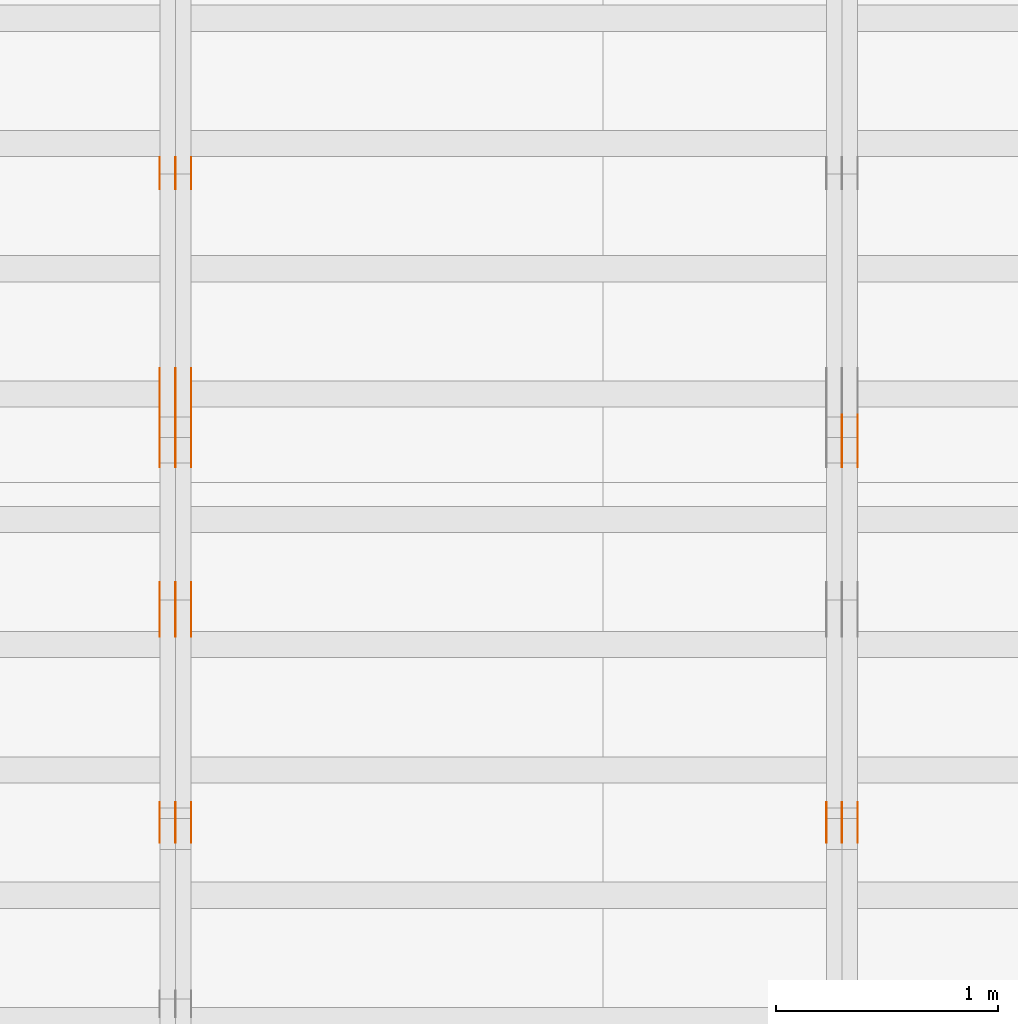
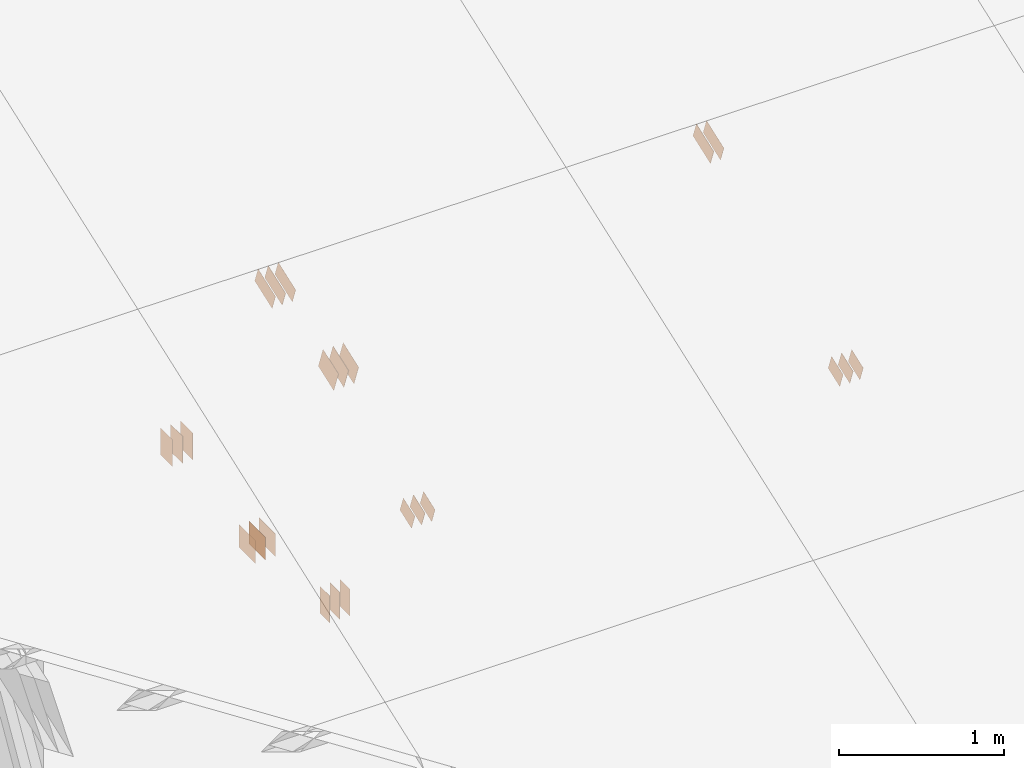
# One storey, part 74 of 189: 31 proxies.
"""IFC2X3 building model written with IfcOpenShell, lengths in millimetres."""

import ifcopenshell
import ifcopenshell.guid

model = None  # the IFC model being written
_history = None  # IfcOwnerHistory: only IFC2X3 demands one
_inside = {}  # id of a spatial element -> (the spatial element, [elements in it])
_under = {}  # id of a project, library or spatial element -> (it, [spatial elements below it])
_declared = {}  # id of a project -> (the project, [libraries it declares])
_typed = {}  # id of a type object -> (the type object, [elements of that type])
_made_of = {}  # id of a material, layer set ... -> (it, [elements and type objects made of it])


def new_model(schema):
    """Start an empty IFC model of exactly this schema.

    Asked for "IFC4X3", IfcOpenShell would pick the latest addendum, in which some entities
    have other attributes; the version numbers below select the first issue.
    IFC2X3 requires an IfcOwnerHistory on every rooted entity: one is made here for all.
    """
    global model, _history
    if schema == "IFC4X3":
        model = ifcopenshell.file(schema_version=(4, 3, 0, 0))
    else:
        model = ifcopenshell.file(schema=schema)
    _inside.clear()
    _under.clear()
    _declared.clear()
    _typed.clear()
    _made_of.clear()
    _history = None
    if model.schema == "IFC2X3":
        org = make("IfcOrganization", Name="unknown")
        user = make(
            "IfcPersonAndOrganization",
            ThePerson=make("IfcPerson", FamilyName="unknown"),
            TheOrganization=org,
        )
        app = make(
            "IfcApplication",
            ApplicationDeveloper=org,
            Version="unknown",
            ApplicationFullName="unknown",
            ApplicationIdentifier="unknown",
        )
        _history = make(
            "IfcOwnerHistory",
            OwningUser=user,
            OwningApplication=app,
            ChangeAction="ADDED",
            CreationDate=0,
        )
    return model


def make(cls, **values):
    """One entity of the class cls with the attributes given. An attribute that is None is left unset."""
    return model.create_entity(
        cls, **{name: value for name, value in values.items() if value is not None}
    )


def entity(cls, *values):
    """Any entity or typed value of the class cls, its attributes in the order of the schema. None: left unset."""
    e = model.create_entity(cls)
    for i, value in enumerate(values):
        if value is not None:
            e[i] = value
    return e


def rooted(cls, **values):
    """An entity with a GlobalId (a new one), such as an element, a storey or a relation."""
    return make(cls, GlobalId=ifcopenshell.guid.new(), OwnerHistory=_history, **values)


def si_unit(unit_type, name, prefix=None):
    """IfcSIUnit, for example si_unit("LENGTHUNIT", "METRE", prefix="MILLI")."""
    return make("IfcSIUnit", UnitType=unit_type, Prefix=prefix, Name=name)


def converted_unit(unit_type, name, factor, base, dimensions=None, offset=None):
    """IfcConversionBasedUnit, such as the inch: factor (a typed value) times the base unit."""
    return make(
        "IfcConversionBasedUnit"
        if offset is None
        else "IfcConversionBasedUnitWithOffset",
        ConversionOffset=offset,
        Dimensions=None
        if dimensions is None
        else entity("IfcDimensionalExponents", *dimensions),
        UnitType=unit_type,
        Name=name,
        ConversionFactor=make(
            "IfcMeasureWithUnit", ValueComponent=factor, UnitComponent=base
        ),
    )


def derived_unit(unit_type, elements):
    """IfcDerivedUnit: a product of units, each with its exponent."""
    return make(
        "IfcDerivedUnit",
        Elements=[
            make("IfcDerivedUnitElement", Unit=unit, Exponent=power)
            for unit, power in elements
        ],
        UnitType=unit_type,
    )


def assignment(units):
    """IfcUnitAssignment: the units of a project."""
    return None if units is None else make("IfcUnitAssignment", Units=units)


def point(xyz):
    """IfcCartesianPoint."""
    return None if xyz is None else make("IfcCartesianPoint", Coordinates=xyz)


def direction(xyz):
    """IfcDirection."""
    return None if xyz is None else make("IfcDirection", DirectionRatios=xyz)


def frame(location, z_axis=None, x_axis=None):
    """IfcAxis2Placement3D, a coordinate frame: its origin and axes. An axis left out is left unset."""
    return make(
        "IfcAxis2Placement3D",
        Location=point(location),
        Axis=direction(z_axis),
        RefDirection=direction(x_axis),
    )


def frame_2d(location, x_axis=None):
    """IfcAxis2Placement2D, a coordinate frame in the plane: its origin and x axis."""
    return make(
        "IfcAxis2Placement2D", Location=point(location), RefDirection=direction(x_axis)
    )


def origin():
    """The frame at (0, 0, 0) with its axes left unset."""
    return frame((0.0, 0.0, 0.0))


def origin_2d_with_axis():
    """The frame at (0, 0) in the plane with the x axis (1, 0) written out."""
    return frame_2d((0.0, 0.0), x_axis=(1.0, 0.0))


def place(relative_to, where):
    """IfcLocalPlacement: puts the frame where relative to a parent placement (None: the world)."""
    return make(
        "IfcLocalPlacement", PlacementRelTo=relative_to, RelativePlacement=where
    )


def context(
    kind, dimensions, precision=None, world=None, true_north=None, identifier=None
):
    """IfcGeometricRepresentationContext, for example the 3D "Model" context."""
    return make(
        "IfcGeometricRepresentationContext",
        ContextIdentifier=identifier,
        ContextType=kind,
        CoordinateSpaceDimension=dimensions,
        Precision=precision,
        WorldCoordinateSystem=world,
        TrueNorth=true_north,
    )


def subcontext(parent, identifier, kind, view, scale=None):
    """IfcGeometricRepresentationSubContext, for example "Body" below "Model"."""
    return make(
        "IfcGeometricRepresentationSubContext",
        ContextIdentifier=identifier,
        ContextType=kind,
        ParentContext=parent,
        TargetScale=scale,
        TargetView=view,
    )


def project(units=None, contexts=None):
    """IfcProject with its units and contexts."""
    return rooted(
        "IfcProject",
        Name="project",
        RepresentationContexts=contexts,
        UnitsInContext=assignment(units),
    )


def spatial(cls, under=None, at=None, **own):
    """A site, building, storey or space (cls), placed at a placement, below another one or the project."""
    s = rooted(cls, ObjectPlacement=at, **own)
    if under is not None:
        _under.setdefault(under.id(), (under, []))[1].append(s)
    return s


def polyline(points):
    """IfcPolyline through the points."""
    return make("IfcPolyline", Points=[point(p) for p in points])


def profile(cls, at=None, kind="AREA", **sizes):
    """A parametric profile (cls). Its sizes go by their IFC names, for example OverallWidth=200.0."""
    return make(cls, ProfileType=kind, Position=at, **sizes)


def rectangle(**sizes):
    """IfcRectangleProfileDef."""
    return profile("IfcRectangleProfileDef", **sizes)


def outline(outer, holes=None, kind="AREA"):
    """IfcArbitraryClosedProfileDef: a profile drawn as a closed curve; with holes, ...WithVoids."""
    if holes is None:
        return make("IfcArbitraryClosedProfileDef", ProfileType=kind, OuterCurve=outer)
    return make(
        "IfcArbitraryProfileDefWithVoids",
        ProfileType=kind,
        OuterCurve=outer,
        InnerCurves=holes,
    )


def extrude(swept, where, along, depth):
    """IfcExtrudedAreaSolid: the profile swept, set in the frame where, extruded along a direction by depth."""
    return make(
        "IfcExtrudedAreaSolid",
        SweptArea=swept,
        Position=where,
        ExtrudedDirection=direction(along),
        Depth=depth,
    )


def shape(context_of_items, identifier, shape_type, items):
    """IfcShapeRepresentation: the items that make up one representation, for example the "Body"."""
    return make(
        "IfcShapeRepresentation",
        ContextOfItems=context_of_items,
        RepresentationIdentifier=identifier,
        RepresentationType=shape_type,
        Items=items,
    )


def source(mapping_origin, context_of_items, identifier, shape_type, items):
    """IfcRepresentationMap: a shape defined once, which mapped items show again and again."""
    return make(
        "IfcRepresentationMap",
        MappingOrigin=mapping_origin,
        MappedRepresentation=shape(context_of_items, identifier, shape_type, items),
    )


def transform(
    local_origin,
    x_axis=None,
    y_axis=None,
    z_axis=None,
    scale=None,
    scale2=None,
    scale3=None,
    uniform=True,
):
    """IfcCartesianTransformationOperator3D, or its non-uniform kind. x_axis, y_axis, z_axis: its Axis1, 2, 3."""
    if uniform:
        return make(
            "IfcCartesianTransformationOperator3D",
            Axis1=direction(x_axis),
            Axis2=direction(y_axis),
            LocalOrigin=point(local_origin),
            Scale=scale,
            Axis3=direction(z_axis),
        )
    return make(
        "IfcCartesianTransformationOperator3DnonUniform",
        Axis1=direction(x_axis),
        Axis2=direction(y_axis),
        LocalOrigin=point(local_origin),
        Scale=scale,
        Axis3=direction(z_axis),
        Scale2=scale2,
        Scale3=scale3,
    )


def mapped(mapping_source, mapping_target):
    """IfcMappedItem: shows the shape of a source again, moved by a transform."""
    return make(
        "IfcMappedItem", MappingSource=mapping_source, MappingTarget=mapping_target
    )


def material(Name=None, Category=None):
    """IfcMaterial."""
    return make("IfcMaterial", Name=Name, Category=Category)


def made_of(thing, what):
    """Note that an element or type object is made of a material, layer set ...; save() writes the relation."""
    if what is not None:
        _made_of.setdefault(what.id(), (what, []))[1].append(thing)
    return thing


def type_object(cls, material=None, **own):
    """A type object (cls), such as IfcWallType, which elements share."""
    return made_of(rooted(cls, **own), material)


def type_shapes(of_type, sources):
    """Give a type object the sources (RepresentationMaps) that its elements show as mapped items."""
    of_type.RepresentationMaps = sources


def element(
    cls,
    number,
    at=None,
    inside=None,
    cuts=None,
    type_object=None,
    material=None,
    context=None,
    identifier="Body",
    shape_type=None,
    held_by="IfcProductDefinitionShape",
    body=None,
    shapes=None,
    **own,
):
    """One element of the class cls, such as IfcWall. Its Tag is "e" and its number.

    at: its placement. inside: the storey or other place that contains it. cuts: it is an
    opening in that element (IfcRelVoidsElement). A single representation is given by context,
    identifier, shape_type and body (its items); several are given by shapes. held_by: the class
    of the entity that holds the representations. save() writes the other relations.
    """
    e = rooted(cls, Tag="e%d" % number, ObjectPlacement=at, **own)
    if body is not None:
        shapes = [shape(context, identifier, shape_type, body)]
    if shapes is not None:
        e.Representation = make(held_by, Representations=shapes)
    if inside is not None:
        _inside.setdefault(inside.id(), (inside, []))[1].append(e)
    if cuts is not None:
        rooted(
            "IfcRelVoidsElement", RelatingBuildingElement=cuts, RelatedOpeningElement=e
        )
    if type_object is not None:
        _typed.setdefault(type_object.id(), (type_object, []))[1].append(e)
    return made_of(e, material)


def aggregate(whole, parts):
    """IfcRelAggregates: a whole, such as a stair, and the parts it consists of."""
    return rooted("IfcRelAggregates", RelatingObject=whole, RelatedObjects=parts)


def save(model, path):
    """Write the relations noted so far, then the file.

    IfcRelAggregates (storeys below a building ...), IfcRelContainedInSpatialStructure (elements
    in a storey), IfcRelDefinesByType, IfcRelAssociatesMaterial and IfcRelDeclares: one each for
    every whole, place, type object, material and project.
    """
    for whole, parts in _under.values():
        aggregate(whole, parts)
    for where, things in _inside.values():
        rooted(
            "IfcRelContainedInSpatialStructure",
            RelatedElements=things,
            RelatingStructure=where,
        )
    for kind, things in _typed.values():
        rooted("IfcRelDefinesByType", RelatedObjects=things, RelatingType=kind)
    for what, things in _made_of.values():
        rooted("IfcRelAssociatesMaterial", RelatedObjects=things, RelatingMaterial=what)
    for by, libraries in _declared.values():
        rooted("IfcRelDeclares", RelatingContext=by, RelatedDefinitions=libraries)
    model.write(path)


model = new_model("IFC2X3")

# Units and contexts
model_context = context("Model", 3, precision=0.01, world=origin(), true_north=direction((6.12303176911189e-17, 1.0)))
body_context = subcontext(model_context, "Body", "Model", "MODEL_VIEW")
ifc_project = project(units=[si_unit("LENGTHUNIT", "METRE", prefix="MILLI"), si_unit("AREAUNIT", "SQUARE_METRE"), si_unit("VOLUMEUNIT", "CUBIC_METRE"), converted_unit("PLANEANGLEUNIT", "DEGREE", entity("IfcRatioMeasure", 0.0174532925199433), si_unit("PLANEANGLEUNIT", "RADIAN"), dimensions=[0, 0, 0, 0, 0, 0, 0]), si_unit("MASSUNIT", "GRAM", prefix="KILO"), derived_unit("MASSDENSITYUNIT", [(si_unit("MASSUNIT", "GRAM", prefix="KILO"), 1), (si_unit("LENGTHUNIT", "METRE"), -3)]), si_unit("TIMEUNIT", "SECOND"), si_unit("FREQUENCYUNIT", "HERTZ"), si_unit("THERMODYNAMICTEMPERATUREUNIT", "DEGREE_CELSIUS"), derived_unit("THERMALTRANSMITTANCEUNIT", [(si_unit("MASSUNIT", "GRAM", prefix="KILO"), 1), (si_unit("THERMODYNAMICTEMPERATUREUNIT", "KELVIN"), -1), (si_unit("TIMEUNIT", "SECOND"), -3)]), derived_unit("VOLUMETRICFLOWRATEUNIT", [(si_unit("LENGTHUNIT", "METRE"), 3), (si_unit("TIMEUNIT", "SECOND"), -1)]), si_unit("ELECTRICCURRENTUNIT", "AMPERE"), si_unit("ELECTRICVOLTAGEUNIT", "VOLT"), si_unit("POWERUNIT", "WATT"), si_unit("FORCEUNIT", "NEWTON"), si_unit("ILLUMINANCEUNIT", "LUX"), si_unit("LUMINOUSFLUXUNIT", "LUMEN"), si_unit("LUMINOUSINTENSITYUNIT", "CANDELA"), derived_unit("USERDEFINED", [(si_unit("MASSUNIT", "GRAM", prefix="KILO"), -1), (si_unit("LENGTHUNIT", "METRE"), -2), (si_unit("TIMEUNIT", "SECOND"), 3), (si_unit("LUMINOUSFLUXUNIT", "LUMEN"), 1)]), derived_unit("LINEARVELOCITYUNIT", [(si_unit("LENGTHUNIT", "METRE"), 1), (si_unit("TIMEUNIT", "SECOND"), -1)]), si_unit("PRESSUREUNIT", "PASCAL"), derived_unit("USERDEFINED", [(si_unit("LENGTHUNIT", "METRE"), -2), (si_unit("MASSUNIT", "GRAM", prefix="KILO"), 1), (si_unit("TIMEUNIT", "SECOND"), -2)])], contexts=[model_context])

# Site, building, storey
site_placement = place(None, origin())
site = spatial("IfcSite", under=ifc_project, at=site_placement, CompositionType="ELEMENT")
building_placement = place(site_placement, origin())
building = spatial("IfcBuilding", under=site, at=building_placement, CompositionType="ELEMENT")
storey_placement = place(building_placement, origin())
storey = spatial("IfcBuildingStorey", under=building, at=storey_placement, Name="Default", CompositionType="ELEMENT", Elevation=0.0)

# Proxies
ifc_material_1 = material(Name="IfcSurfaceStyle #75126")
building_element_proxy_type_1 = type_object("IfcBuildingElementProxyType", PredefinedType="NOTDEFINED", material=ifc_material_1)
shared_shape_1 = source(origin(), body_context, "Body", "SweptSolid", [
    extrude(outline(polyline([(-112.500654374667, -59.9999021691247), (112.500117969231, -59.9999021691247), (112.500612624162, 59.9999021691247), (-112.500076218726, 59.9999021691247), (-112.500654374667, -59.9999021691247)])), frame((112.500612624162, 60.0003514046321, 0.0), z_axis=(0.0, 0.0, 1.0), x_axis=(-1.0, 0.0, 0.0)), (0.0, 0.0, 1.0), 1.3),
])
type_shapes(building_element_proxy_type_1, [shared_shape_1])
proxy_1_placement = place(building_placement, frame((12301.3, 5418.0703125, 2162.37353515625), z_axis=(-1.0, 0.0, 0.0), x_axis=(0.0, 0.939692620785908, 0.342020143325669)))
element("IfcBuildingElementProxy", 1, at=proxy_1_placement, inside=storey, type_object=building_element_proxy_type_1, material=ifc_material_1, context=body_context, shape_type="MappedRepresentation", body=[
    mapped(shared_shape_1, transform((0.0, 0.0, 0.0), scale=1.0)),
])
ifc_material_2 = material(Name="IfcSurfaceStyle #75069")
building_element_proxy_type_2 = type_object("IfcBuildingElementProxyType", PredefinedType="NOTDEFINED", material=ifc_material_2)
shared_shape_2 = source(origin(), body_context, "Body", "SweptSolid", [
    extrude(outline(polyline([(-112.500654374667, -59.9999021691247), (112.500117969231, -59.9999021691247), (112.500612624162, 59.9999021691247), (-112.500076218726, 59.9999021691247), (-112.500654374667, -59.9999021691247)])), frame((112.500612624162, 60.0003514046321, 0.0), z_axis=(0.0, 0.0, 1.0), x_axis=(-1.0, 0.0, 0.0)), (0.0, 0.0, 1.0), 1.29999999999998),
])
type_shapes(building_element_proxy_type_2, [shared_shape_2])
proxy_2_placement = place(building_placement, frame((12230.0, 5418.0703125, 2162.37353515625), z_axis=(-1.0, 0.0, 0.0), x_axis=(0.0, 0.939692620785908, 0.342020143325669)))
element("IfcBuildingElementProxy", 2, at=proxy_2_placement, inside=storey, type_object=building_element_proxy_type_2, material=ifc_material_2, context=body_context, shape_type="MappedRepresentation", body=[
    mapped(shared_shape_2, transform((0.0, 0.0, 0.0), scale=1.0)),
])
ifc_material_3 = material(Name="IfcSurfaceStyle #75012")
building_element_proxy_type_3 = type_object("IfcBuildingElementProxyType", PredefinedType="NOTDEFINED", material=ifc_material_3)
shared_shape_3 = source(origin(), body_context, "Body", "SweptSolid", [
    extrude(outline(polyline([(-112.500654374667, -59.9999021691247), (112.500117969231, -59.9999021691247), (112.500612624162, 59.9999021691247), (-112.500076218726, 59.9999021691247), (-112.500654374667, -59.9999021691247)])), frame((112.500612624162, 60.0003514046321, 0.0), z_axis=(0.0, 0.0, 1.0), x_axis=(-1.0, 0.0, 0.0)), (0.0, 0.0, 1.0), 1.29999999999998),
])
type_shapes(building_element_proxy_type_3, [shared_shape_3])
proxy_3_placement = place(building_placement, frame((12231.3, 5418.0703125, 2162.37353515625), z_axis=(-1.0, 0.0, 0.0), x_axis=(0.0, 0.939692620785908, 0.342020143325669)))
element("IfcBuildingElementProxy", 3, at=proxy_3_placement, inside=storey, type_object=building_element_proxy_type_3, material=ifc_material_3, context=body_context, shape_type="MappedRepresentation", body=[
    mapped(shared_shape_3, transform((0.0, 0.0, 0.0), scale=1.0)),
])
ifc_material_4 = material(Name="IfcSurfaceStyle #74214")
building_element_proxy_type_4 = type_object("IfcBuildingElementProxyType", PredefinedType="NOTDEFINED", material=ifc_material_4)
shared_shape_4 = source(origin(), body_context, "Body", "SweptSolid", [
    extrude(outline(polyline([(-74.9994515581384, -59.9999039432178), (74.9998536965286, -59.9999039432178), (75.0003483514593, 59.9999039432178), (-75.0007504898495, 59.9999039432178), (-74.9994515581384, -59.9999039432178)])), frame((75.0003483514593, 60.0003496305408, 0.0), z_axis=(0.0, 0.0, 1.0), x_axis=(-1.0, 0.0, 0.0)), (0.0, 0.0, 1.0), 1.3),
])
type_shapes(building_element_proxy_type_4, [shared_shape_4])
proxy_4_placement = place(building_placement, frame((12301.3, 3726.8984375, 1559.607421875), z_axis=(-1.0, 0.0, 0.0), x_axis=(0.0, 0.939692620785908, 0.342020143325669)))
element("IfcBuildingElementProxy", 4, at=proxy_4_placement, inside=storey, type_object=building_element_proxy_type_4, material=ifc_material_4, context=body_context, shape_type="MappedRepresentation", body=[
    mapped(shared_shape_4, transform((0.0, 0.0, 0.0), scale=1.0)),
])
ifc_material_5 = material(Name="IfcSurfaceStyle #74157")
building_element_proxy_type_5 = type_object("IfcBuildingElementProxyType", PredefinedType="NOTDEFINED", material=ifc_material_5)
shared_shape_5 = source(origin(), body_context, "Body", "SweptSolid", [
    extrude(outline(polyline([(-74.9994515581384, -59.9999039432178), (74.9998536965286, -59.9999039432178), (75.0003483514593, 59.9999039432178), (-75.0007504898495, 59.9999039432178), (-74.9994515581384, -59.9999039432178)])), frame((75.0003483514593, 60.0003496305408, 0.0), z_axis=(0.0, 0.0, 1.0), x_axis=(-1.0, 0.0, 0.0)), (0.0, 0.0, 1.0), 1.29999999999999),
])
type_shapes(building_element_proxy_type_5, [shared_shape_5])
proxy_5_placement = place(building_placement, frame((12230.0, 3726.8984375, 1559.607421875), z_axis=(-1.0, 0.0, 0.0), x_axis=(0.0, 0.939692620785908, 0.342020143325669)))
element("IfcBuildingElementProxy", 5, at=proxy_5_placement, inside=storey, type_object=building_element_proxy_type_5, material=ifc_material_5, context=body_context, shape_type="MappedRepresentation", body=[
    mapped(shared_shape_5, transform((0.0, 0.0, 0.0), scale=1.0)),
])
ifc_material_6 = material(Name="IfcSurfaceStyle #74100")
building_element_proxy_type_6 = type_object("IfcBuildingElementProxyType", PredefinedType="NOTDEFINED", material=ifc_material_6)
shared_shape_6 = source(origin(), body_context, "Body", "SweptSolid", [
    extrude(outline(polyline([(-74.9994515581384, -59.9999039432178), (74.9998536965286, -59.9999039432178), (75.0003483514593, 59.9999039432178), (-75.0007504898495, 59.9999039432178), (-74.9994515581384, -59.9999039432178)])), frame((75.0003483514593, 60.0003496305408, 0.0), z_axis=(0.0, 0.0, 1.0), x_axis=(-1.0, 0.0, 0.0)), (0.0, 0.0, 1.0), 1.29999999999999),
])
type_shapes(building_element_proxy_type_6, [shared_shape_6])
proxy_6_placement = place(building_placement, frame((12231.3, 3726.8984375, 1559.607421875), z_axis=(-1.0, 0.0, 0.0), x_axis=(0.0, 0.939692620785908, 0.342020143325669)))
element("IfcBuildingElementProxy", 6, at=proxy_6_placement, inside=storey, type_object=building_element_proxy_type_6, material=ifc_material_6, context=body_context, shape_type="MappedRepresentation", body=[
    mapped(shared_shape_6, transform((0.0, 0.0, 0.0), scale=1.0)),
])
ifc_material_7 = material(Name="IfcSurfaceStyle #74043")
building_element_proxy_type_7 = type_object("IfcBuildingElementProxyType", PredefinedType="NOTDEFINED", material=ifc_material_7)
shared_shape_7 = source(origin(), body_context, "Body", "SweptSolid", [
    extrude(outline(polyline([(-74.9994515581384, -59.9999039432178), (74.9998536965286, -59.9999039432178), (75.0003483514593, 59.9999039432178), (-75.0007504898495, 59.9999039432178), (-74.9994515581384, -59.9999039432178)])), frame((75.0003483514593, 60.0003496305408, 0.0), z_axis=(0.0, 0.0, 1.0), x_axis=(-1.0, 0.0, 0.0)), (0.0, 0.0, 1.0), 1.29999999999999),
])
type_shapes(building_element_proxy_type_7, [shared_shape_7])
proxy_7_placement = place(building_placement, frame((12160.0, 3726.8984375, 1559.607421875), z_axis=(-1.0, 0.0, 0.0), x_axis=(0.0, 0.939692620785908, 0.342020143325669)))
element("IfcBuildingElementProxy", 7, at=proxy_7_placement, inside=storey, type_object=building_element_proxy_type_7, material=ifc_material_7, context=body_context, shape_type="MappedRepresentation", body=[
    mapped(shared_shape_7, transform((0.0, 0.0, 0.0), scale=1.0)),
])
ifc_material_8 = material(Name="IfcSurfaceStyle #63212")
building_element_proxy_type_8 = type_object("IfcBuildingElementProxyType", PredefinedType="NOTDEFINED", material=ifc_material_8)
shared_shape_8 = source(origin(), body_context, "Body", "SweptSolid", [
    extrude(rectangle(XDim=200.0, YDim=144.0, at=frame_2d((1.4210854715202e-14, 0.0), x_axis=(1.0, 0.0))), frame((100.0, 72.0, 0.0), z_axis=(0.0, 0.0, 1.0), x_axis=(-1.0, 0.0, 0.0)), (0.0, 0.0, 1.0), 1.3),
])
type_shapes(building_element_proxy_type_8, [shared_shape_8])
proxy_8_placement = place(building_placement, frame((9301.3, 6668.833984375, 145.0), z_axis=(-1.0, 0.0, 0.0), x_axis=(0.0, 0.0, 1.0)))
element("IfcBuildingElementProxy", 8, at=proxy_8_placement, inside=storey, type_object=building_element_proxy_type_8, material=ifc_material_8, context=body_context, shape_type="MappedRepresentation", body=[
    mapped(shared_shape_8, transform((0.0, 0.0, 0.0), scale=1.0)),
])
ifc_material_9 = material(Name="IfcSurfaceStyle #63155")
building_element_proxy_type_9 = type_object("IfcBuildingElementProxyType", PredefinedType="NOTDEFINED", material=ifc_material_9)
shared_shape_9 = source(origin(), body_context, "Body", "SweptSolid", [
    extrude(rectangle(XDim=200.0, YDim=144.0, at=frame_2d((1.4210854715202e-14, 0.0), x_axis=(1.0, 0.0))), frame((100.0, 72.0, 0.0), z_axis=(0.0, 0.0, 1.0), x_axis=(-1.0, 0.0, 0.0)), (0.0, 0.0, 1.0), 1.29999999999998),
])
type_shapes(building_element_proxy_type_9, [shared_shape_9])
proxy_9_placement = place(building_placement, frame((9230.0, 6668.833984375, 145.0), z_axis=(-1.0, 0.0, 0.0), x_axis=(0.0, 0.0, 1.0)))
element("IfcBuildingElementProxy", 9, at=proxy_9_placement, inside=storey, type_object=building_element_proxy_type_9, material=ifc_material_9, context=body_context, shape_type="MappedRepresentation", body=[
    mapped(shared_shape_9, transform((0.0, 0.0, 0.0), scale=1.0)),
])
ifc_material_10 = material(Name="IfcSurfaceStyle #63098")
building_element_proxy_type_10 = type_object("IfcBuildingElementProxyType", PredefinedType="NOTDEFINED", material=ifc_material_10)
shared_shape_10 = source(origin(), body_context, "Body", "SweptSolid", [
    extrude(rectangle(XDim=200.0, YDim=144.0, at=frame_2d((1.4210854715202e-14, 0.0), x_axis=(1.0, 0.0))), frame((100.0, 72.0, 0.0), z_axis=(0.0, 0.0, 1.0), x_axis=(-1.0, 0.0, 0.0)), (0.0, 0.0, 1.0), 1.29999999999998),
])
type_shapes(building_element_proxy_type_10, [shared_shape_10])
proxy_10_placement = place(building_placement, frame((9231.3, 6668.833984375, 145.0), z_axis=(-1.0, 0.0, 0.0), x_axis=(0.0, 0.0, 1.0)))
element("IfcBuildingElementProxy", 10, at=proxy_10_placement, inside=storey, type_object=building_element_proxy_type_10, material=ifc_material_10, context=body_context, shape_type="MappedRepresentation", body=[
    mapped(shared_shape_10, transform((0.0, 0.0, 0.0), scale=1.0)),
])
ifc_material_11 = material(Name="IfcSurfaceStyle #63041")
building_element_proxy_type_11 = type_object("IfcBuildingElementProxyType", PredefinedType="NOTDEFINED", material=ifc_material_11)
shared_shape_11 = source(origin(), body_context, "Body", "SweptSolid", [
    extrude(rectangle(XDim=200.0, YDim=144.0, at=frame_2d((1.4210854715202e-14, 0.0), x_axis=(1.0, 0.0))), frame((100.0, 72.0, 0.0), z_axis=(0.0, 0.0, 1.0), x_axis=(-1.0, 0.0, 0.0)), (0.0, 0.0, 1.0), 1.29999999999999),
])
type_shapes(building_element_proxy_type_11, [shared_shape_11])
proxy_11_placement = place(building_placement, frame((9160.0, 6668.833984375, 145.0), z_axis=(-1.0, 0.0, 0.0), x_axis=(0.0, 0.0, 1.0)))
element("IfcBuildingElementProxy", 11, at=proxy_11_placement, inside=storey, type_object=building_element_proxy_type_11, material=ifc_material_11, context=body_context, shape_type="MappedRepresentation", body=[
    mapped(shared_shape_11, transform((0.0, 0.0, 0.0), scale=1.0)),
])
ifc_material_12 = material(Name="IfcSurfaceStyle #62984")
building_element_proxy_type_12 = type_object("IfcBuildingElementProxyType", PredefinedType="NOTDEFINED", material=ifc_material_12)
shared_shape_12 = source(origin(), body_context, "Body", "SweptSolid", [
    extrude(rectangle(XDim=200.0, YDim=168.0, at=origin_2d_with_axis()), frame((100.0, 84.0, 0.0), z_axis=(0.0, 0.0, 1.0), x_axis=(-1.0, 0.0, 0.0)), (0.0, 0.0, 1.0), 1.3),
])
type_shapes(building_element_proxy_type_12, [shared_shape_12])
proxy_12_placement = place(building_placement, frame((9301.3, 5662.466796875, 206.5), z_axis=(-1.0, 0.0, 0.0), x_axis=(0.0, 1.0, 0.0)))
element("IfcBuildingElementProxy", 12, at=proxy_12_placement, inside=storey, type_object=building_element_proxy_type_12, material=ifc_material_12, context=body_context, shape_type="MappedRepresentation", body=[
    mapped(shared_shape_12, transform((0.0, 0.0, 0.0), scale=1.0)),
])
ifc_material_13 = material(Name="IfcSurfaceStyle #62927")
building_element_proxy_type_13 = type_object("IfcBuildingElementProxyType", PredefinedType="NOTDEFINED", material=ifc_material_13)
shared_shape_13 = source(origin(), body_context, "Body", "SweptSolid", [
    extrude(rectangle(XDim=200.0, YDim=168.0, at=origin_2d_with_axis()), frame((100.0, 84.0, 0.0), z_axis=(0.0, 0.0, 1.0), x_axis=(-1.0, 0.0, 0.0)), (0.0, 0.0, 1.0), 1.29999999999998),
])
type_shapes(building_element_proxy_type_13, [shared_shape_13])
proxy_13_placement = place(building_placement, frame((9230.0, 5662.466796875, 206.5), z_axis=(-1.0, 0.0, 0.0), x_axis=(0.0, 1.0, 0.0)))
element("IfcBuildingElementProxy", 13, at=proxy_13_placement, inside=storey, type_object=building_element_proxy_type_13, material=ifc_material_13, context=body_context, shape_type="MappedRepresentation", body=[
    mapped(shared_shape_13, transform((0.0, 0.0, 0.0), scale=1.0)),
])
ifc_material_14 = material(Name="IfcSurfaceStyle #62870")
building_element_proxy_type_14 = type_object("IfcBuildingElementProxyType", PredefinedType="NOTDEFINED", material=ifc_material_14)
shared_shape_14 = source(origin(), body_context, "Body", "SweptSolid", [
    extrude(rectangle(XDim=200.0, YDim=168.0, at=origin_2d_with_axis()), frame((100.0, 84.0, 0.0), z_axis=(0.0, 0.0, 1.0), x_axis=(-1.0, 0.0, 0.0)), (0.0, 0.0, 1.0), 1.29999999999998),
])
type_shapes(building_element_proxy_type_14, [shared_shape_14])
proxy_14_placement = place(building_placement, frame((9231.3, 5662.466796875, 206.5), z_axis=(-1.0, 0.0, 0.0), x_axis=(0.0, 1.0, 0.0)))
element("IfcBuildingElementProxy", 14, at=proxy_14_placement, inside=storey, type_object=building_element_proxy_type_14, material=ifc_material_14, context=body_context, shape_type="MappedRepresentation", body=[
    mapped(shared_shape_14, transform((0.0, 0.0, 0.0), scale=1.0)),
])
ifc_material_15 = material(Name="IfcSurfaceStyle #62813")
building_element_proxy_type_15 = type_object("IfcBuildingElementProxyType", PredefinedType="NOTDEFINED", material=ifc_material_15)
shared_shape_15 = source(origin(), body_context, "Body", "SweptSolid", [
    extrude(rectangle(XDim=200.0, YDim=168.0, at=origin_2d_with_axis()), frame((100.0, 84.0, 0.0), z_axis=(0.0, 0.0, 1.0), x_axis=(-1.0, 0.0, 0.0)), (0.0, 0.0, 1.0), 1.29999999999999),
])
type_shapes(building_element_proxy_type_15, [shared_shape_15])
proxy_15_placement = place(building_placement, frame((9160.0, 5662.466796875, 206.5), z_axis=(-1.0, 0.0, 0.0), x_axis=(0.0, 1.0, 0.0)))
element("IfcBuildingElementProxy", 15, at=proxy_15_placement, inside=storey, type_object=building_element_proxy_type_15, material=ifc_material_15, context=body_context, shape_type="MappedRepresentation", body=[
    mapped(shared_shape_15, transform((0.0, 0.0, 0.0), scale=1.0)),
])
ifc_material_16 = material(Name="IfcSurfaceStyle #59336")
building_element_proxy_type_16 = type_object("IfcBuildingElementProxyType", PredefinedType="NOTDEFINED", material=ifc_material_16)
shared_shape_16 = source(origin(), body_context, "Body", "SweptSolid", [
    extrude(outline(polyline([(-112.500654374667, -59.9999021691247), (112.500117969231, -59.9999021691247), (112.500612624162, 59.9999021691247), (-112.500076218726, 59.9999021691247), (-112.500654374667, -59.9999021691247)])), frame((112.500612624162, 60.0003514046321, 0.0), z_axis=(0.0, 0.0, 1.0), x_axis=(-1.0, 0.0, 0.0)), (0.0, 0.0, 1.0), 1.3),
])
type_shapes(building_element_proxy_type_16, [shared_shape_16])
proxy_16_placement = place(building_placement, frame((9301.3, 5418.0703125, 2162.37353515625), z_axis=(-1.0, 0.0, 0.0), x_axis=(0.0, 0.939692620785908, 0.342020143325669)))
element("IfcBuildingElementProxy", 16, at=proxy_16_placement, inside=storey, type_object=building_element_proxy_type_16, material=ifc_material_16, context=body_context, shape_type="MappedRepresentation", body=[
    mapped(shared_shape_16, transform((0.0, 0.0, 0.0), scale=1.0)),
])
ifc_material_17 = material(Name="IfcSurfaceStyle #59279")
building_element_proxy_type_17 = type_object("IfcBuildingElementProxyType", PredefinedType="NOTDEFINED", material=ifc_material_17)
shared_shape_17 = source(origin(), body_context, "Body", "SweptSolid", [
    extrude(outline(polyline([(-112.500654374667, -59.9999021691247), (112.500117969231, -59.9999021691247), (112.500612624162, 59.9999021691247), (-112.500076218726, 59.9999021691247), (-112.500654374667, -59.9999021691247)])), frame((112.500612624162, 60.0003514046321, 0.0), z_axis=(0.0, 0.0, 1.0), x_axis=(-1.0, 0.0, 0.0)), (0.0, 0.0, 1.0), 1.29999999999998),
])
type_shapes(building_element_proxy_type_17, [shared_shape_17])
proxy_17_placement = place(building_placement, frame((9230.0, 5418.0703125, 2162.37353515625), z_axis=(-1.0, 0.0, 0.0), x_axis=(0.0, 0.939692620785908, 0.342020143325669)))
element("IfcBuildingElementProxy", 17, at=proxy_17_placement, inside=storey, type_object=building_element_proxy_type_17, material=ifc_material_17, context=body_context, shape_type="MappedRepresentation", body=[
    mapped(shared_shape_17, transform((0.0, 0.0, 0.0), scale=1.0)),
])
ifc_material_18 = material(Name="IfcSurfaceStyle #59222")
building_element_proxy_type_18 = type_object("IfcBuildingElementProxyType", PredefinedType="NOTDEFINED", material=ifc_material_18)
shared_shape_18 = source(origin(), body_context, "Body", "SweptSolid", [
    extrude(outline(polyline([(-112.500654374667, -59.9999021691247), (112.500117969231, -59.9999021691247), (112.500612624162, 59.9999021691247), (-112.500076218726, 59.9999021691247), (-112.500654374667, -59.9999021691247)])), frame((112.500612624162, 60.0003514046321, 0.0), z_axis=(0.0, 0.0, 1.0), x_axis=(-1.0, 0.0, 0.0)), (0.0, 0.0, 1.0), 1.29999999999998),
])
type_shapes(building_element_proxy_type_18, [shared_shape_18])
proxy_18_placement = place(building_placement, frame((9231.3, 5418.0703125, 2162.37353515625), z_axis=(-1.0, 0.0, 0.0), x_axis=(0.0, 0.939692620785908, 0.342020143325669)))
element("IfcBuildingElementProxy", 18, at=proxy_18_placement, inside=storey, type_object=building_element_proxy_type_18, material=ifc_material_18, context=body_context, shape_type="MappedRepresentation", body=[
    mapped(shared_shape_18, transform((0.0, 0.0, 0.0), scale=1.0)),
])
ifc_material_19 = material(Name="IfcSurfaceStyle #59165")
building_element_proxy_type_19 = type_object("IfcBuildingElementProxyType", PredefinedType="NOTDEFINED", material=ifc_material_19)
shared_shape_19 = source(origin(), body_context, "Body", "SweptSolid", [
    extrude(outline(polyline([(-112.500654374667, -59.9999021691247), (112.500117969231, -59.9999021691247), (112.500612624162, 59.9999021691247), (-112.500076218726, 59.9999021691247), (-112.500654374667, -59.9999021691247)])), frame((112.500612624162, 60.0003514046321, 0.0), z_axis=(0.0, 0.0, 1.0), x_axis=(-1.0, 0.0, 0.0)), (0.0, 0.0, 1.0), 1.29999999999999),
])
type_shapes(building_element_proxy_type_19, [shared_shape_19])
proxy_19_placement = place(building_placement, frame((9160.0, 5418.0703125, 2162.37353515625), z_axis=(-1.0, 0.0, 0.0), x_axis=(0.0, 0.939692620785908, 0.342020143325669)))
element("IfcBuildingElementProxy", 19, at=proxy_19_placement, inside=storey, type_object=building_element_proxy_type_19, material=ifc_material_19, context=body_context, shape_type="MappedRepresentation", body=[
    mapped(shared_shape_19, transform((0.0, 0.0, 0.0), scale=1.0)),
])
ifc_material_20 = material(Name="IfcSurfaceStyle #58652")
building_element_proxy_type_20 = type_object("IfcBuildingElementProxyType", PredefinedType="NOTDEFINED", material=ifc_material_20)
shared_shape_20 = source(origin(), body_context, "Body", "SweptSolid", [
    extrude(rectangle(XDim=200.0, YDim=120.0, at=origin_2d_with_axis()), frame((100.0, 60.0, 0.0), z_axis=(0.0, 0.0, 1.0), x_axis=(-1.0, 0.0, 0.0)), (0.0, 0.0, 1.0), 1.3),
])
type_shapes(building_element_proxy_type_20, [shared_shape_20])
proxy_20_placement = place(building_placement, frame((9301.3, 4760.65625, 145.0), z_axis=(-1.0, 0.0, 0.0), x_axis=(0.0, 0.0, 1.0)))
element("IfcBuildingElementProxy", 20, at=proxy_20_placement, inside=storey, type_object=building_element_proxy_type_20, material=ifc_material_20, context=body_context, shape_type="MappedRepresentation", body=[
    mapped(shared_shape_20, transform((0.0, 0.0, 0.0), scale=1.0)),
])
ifc_material_21 = material(Name="IfcSurfaceStyle #58595")
building_element_proxy_type_21 = type_object("IfcBuildingElementProxyType", PredefinedType="NOTDEFINED", material=ifc_material_21)
shared_shape_21 = source(origin(), body_context, "Body", "SweptSolid", [
    extrude(rectangle(XDim=200.0, YDim=120.0, at=origin_2d_with_axis()), frame((100.0, 60.0, 0.0), z_axis=(0.0, 0.0, 1.0), x_axis=(-1.0, 0.0, 0.0)), (0.0, 0.0, 1.0), 1.29999999999998),
])
type_shapes(building_element_proxy_type_21, [shared_shape_21])
proxy_21_placement = place(building_placement, frame((9230.0, 4760.65625, 145.0), z_axis=(-1.0, 0.0, 0.0), x_axis=(0.0, 0.0, 1.0)))
element("IfcBuildingElementProxy", 21, at=proxy_21_placement, inside=storey, type_object=building_element_proxy_type_21, material=ifc_material_21, context=body_context, shape_type="MappedRepresentation", body=[
    mapped(shared_shape_21, transform((0.0, 0.0, 0.0), scale=1.0)),
])
ifc_material_22 = material(Name="IfcSurfaceStyle #58538")
building_element_proxy_type_22 = type_object("IfcBuildingElementProxyType", PredefinedType="NOTDEFINED", material=ifc_material_22)
shared_shape_22 = source(origin(), body_context, "Body", "SweptSolid", [
    extrude(rectangle(XDim=200.0, YDim=120.0, at=origin_2d_with_axis()), frame((100.0, 60.0, 0.0), z_axis=(0.0, 0.0, 1.0), x_axis=(-1.0, 0.0, 0.0)), (0.0, 0.0, 1.0), 1.29999999999998),
])
type_shapes(building_element_proxy_type_22, [shared_shape_22])
proxy_22_placement = place(building_placement, frame((9231.3, 4760.65625, 145.0), z_axis=(-1.0, 0.0, 0.0), x_axis=(0.0, 0.0, 1.0)))
element("IfcBuildingElementProxy", 22, at=proxy_22_placement, inside=storey, type_object=building_element_proxy_type_22, material=ifc_material_22, context=body_context, shape_type="MappedRepresentation", body=[
    mapped(shared_shape_22, transform((0.0, 0.0, 0.0), scale=1.0)),
])
ifc_material_23 = material(Name="IfcSurfaceStyle #58481")
building_element_proxy_type_23 = type_object("IfcBuildingElementProxyType", PredefinedType="NOTDEFINED", material=ifc_material_23)
shared_shape_23 = source(origin(), body_context, "Body", "SweptSolid", [
    extrude(rectangle(XDim=200.0, YDim=120.0, at=origin_2d_with_axis()), frame((100.0, 60.0, 0.0), z_axis=(0.0, 0.0, 1.0), x_axis=(-1.0, 0.0, 0.0)), (0.0, 0.0, 1.0), 1.29999999999999),
])
type_shapes(building_element_proxy_type_23, [shared_shape_23])
proxy_23_placement = place(building_placement, frame((9160.0, 4760.65625, 145.0), z_axis=(-1.0, 0.0, 0.0), x_axis=(0.0, 0.0, 1.0)))
element("IfcBuildingElementProxy", 23, at=proxy_23_placement, inside=storey, type_object=building_element_proxy_type_23, material=ifc_material_23, context=body_context, shape_type="MappedRepresentation", body=[
    mapped(shared_shape_23, transform((0.0, 0.0, 0.0), scale=1.0)),
])
ifc_material_24 = material(Name="IfcSurfaceStyle #58424")
building_element_proxy_type_24 = type_object("IfcBuildingElementProxyType", PredefinedType="NOTDEFINED", material=ifc_material_24)
shared_shape_24 = source(origin(), body_context, "Body", "SweptSolid", [
    extrude(outline(polyline([(-74.9994515581384, -59.9999039432178), (74.9998536965286, -59.9999039432178), (75.0003483514593, 59.9999039432178), (-75.0007504898495, 59.9999039432178), (-74.9994515581384, -59.9999039432178)])), frame((75.0003483514593, 60.0003496305408, 0.0), z_axis=(0.0, 0.0, 1.0), x_axis=(-1.0, 0.0, 0.0)), (0.0, 0.0, 1.0), 1.3),
])
type_shapes(building_element_proxy_type_24, [shared_shape_24])
proxy_24_placement = place(building_placement, frame((9301.3, 3726.8984375, 1559.607421875), z_axis=(-1.0, 0.0, 0.0), x_axis=(0.0, 0.939692620785908, 0.342020143325669)))
element("IfcBuildingElementProxy", 24, at=proxy_24_placement, inside=storey, type_object=building_element_proxy_type_24, material=ifc_material_24, context=body_context, shape_type="MappedRepresentation", body=[
    mapped(shared_shape_24, transform((0.0, 0.0, 0.0), scale=1.0)),
])
ifc_material_25 = material(Name="IfcSurfaceStyle #58367")
building_element_proxy_type_25 = type_object("IfcBuildingElementProxyType", PredefinedType="NOTDEFINED", material=ifc_material_25)
shared_shape_25 = source(origin(), body_context, "Body", "SweptSolid", [
    extrude(outline(polyline([(-74.9994515581384, -59.9999039432178), (74.9998536965286, -59.9999039432178), (75.0003483514593, 59.9999039432178), (-75.0007504898495, 59.9999039432178), (-74.9994515581384, -59.9999039432178)])), frame((75.0003483514593, 60.0003496305408, 0.0), z_axis=(0.0, 0.0, 1.0), x_axis=(-1.0, 0.0, 0.0)), (0.0, 0.0, 1.0), 1.29999999999999),
])
type_shapes(building_element_proxy_type_25, [shared_shape_25])
proxy_25_placement = place(building_placement, frame((9230.0, 3726.8984375, 1559.607421875), z_axis=(-1.0, 0.0, 0.0), x_axis=(0.0, 0.939692620785908, 0.342020143325669)))
element("IfcBuildingElementProxy", 25, at=proxy_25_placement, inside=storey, type_object=building_element_proxy_type_25, material=ifc_material_25, context=body_context, shape_type="MappedRepresentation", body=[
    mapped(shared_shape_25, transform((0.0, 0.0, 0.0), scale=1.0)),
])
ifc_material_26 = material(Name="IfcSurfaceStyle #58310")
building_element_proxy_type_26 = type_object("IfcBuildingElementProxyType", PredefinedType="NOTDEFINED", material=ifc_material_26)
shared_shape_26 = source(origin(), body_context, "Body", "SweptSolid", [
    extrude(outline(polyline([(-74.9994515581384, -59.9999039432178), (74.9998536965286, -59.9999039432178), (75.0003483514593, 59.9999039432178), (-75.0007504898495, 59.9999039432178), (-74.9994515581384, -59.9999039432178)])), frame((75.0003483514593, 60.0003496305408, 0.0), z_axis=(0.0, 0.0, 1.0), x_axis=(-1.0, 0.0, 0.0)), (0.0, 0.0, 1.0), 1.29999999999999),
])
type_shapes(building_element_proxy_type_26, [shared_shape_26])
proxy_26_placement = place(building_placement, frame((9231.3, 3726.8984375, 1559.607421875), z_axis=(-1.0, 0.0, 0.0), x_axis=(0.0, 0.939692620785908, 0.342020143325669)))
element("IfcBuildingElementProxy", 26, at=proxy_26_placement, inside=storey, type_object=building_element_proxy_type_26, material=ifc_material_26, context=body_context, shape_type="MappedRepresentation", body=[
    mapped(shared_shape_26, transform((0.0, 0.0, 0.0), scale=1.0)),
])
ifc_material_27 = material(Name="IfcSurfaceStyle #58253")
building_element_proxy_type_27 = type_object("IfcBuildingElementProxyType", PredefinedType="NOTDEFINED", material=ifc_material_27)
shared_shape_27 = source(origin(), body_context, "Body", "SweptSolid", [
    extrude(outline(polyline([(-74.9994515581384, -59.9999039432178), (74.9998536965286, -59.9999039432178), (75.0003483514593, 59.9999039432178), (-75.0007504898495, 59.9999039432178), (-74.9994515581384, -59.9999039432178)])), frame((75.0003483514593, 60.0003496305408, 0.0), z_axis=(0.0, 0.0, 1.0), x_axis=(-1.0, 0.0, 0.0)), (0.0, 0.0, 1.0), 1.29999999999999),
])
type_shapes(building_element_proxy_type_27, [shared_shape_27])
proxy_27_placement = place(building_placement, frame((9160.0, 3726.8984375, 1559.607421875), z_axis=(-1.0, 0.0, 0.0), x_axis=(0.0, 0.939692620785908, 0.342020143325669)))
element("IfcBuildingElementProxy", 27, at=proxy_27_placement, inside=storey, type_object=building_element_proxy_type_27, material=ifc_material_27, context=body_context, shape_type="MappedRepresentation", body=[
    mapped(shared_shape_27, transform((0.0, 0.0, 0.0), scale=1.0)),
])
ifc_material_28 = material(Name="IfcSurfaceStyle #53756")
building_element_proxy_type_28 = type_object("IfcBuildingElementProxyType", PredefinedType="NOTDEFINED", material=ifc_material_28)
shared_shape_28 = source(origin(), body_context, "Body", "SweptSolid", [
    extrude(outline(polyline([(-99.9993269270171, -84.0000832532405), (99.9997189122032, -84.0000832532405), (99.9992851765118, 84.0000832532405), (-99.999677161698, 84.0000832532405), (-99.9993269270171, -84.0000832532405)])), frame((99.9999283659736, 84.0000832532405, 0.0), z_axis=(0.0, 0.0, 1.0), x_axis=(-1.0, 0.0, 0.0)), (0.0, 0.0, 1.0), 1.3),
])
type_shapes(building_element_proxy_type_28, [shared_shape_28])
proxy_28_placement = place(building_placement, frame((9301.3, 4654.06379965055, 2052.96988554922), z_axis=(-1.0, 0.0, 0.0), x_axis=(0.0, 0.939692620785908, 0.342020143325669)))
element("IfcBuildingElementProxy", 28, at=proxy_28_placement, inside=storey, type_object=building_element_proxy_type_28, material=ifc_material_28, context=body_context, shape_type="MappedRepresentation", body=[
    mapped(shared_shape_28, transform((0.0, 0.0, 0.0), scale=1.0)),
])
ifc_material_29 = material(Name="IfcSurfaceStyle #53699")
building_element_proxy_type_29 = type_object("IfcBuildingElementProxyType", PredefinedType="NOTDEFINED", material=ifc_material_29)
shared_shape_29 = source(origin(), body_context, "Body", "SweptSolid", [
    extrude(outline(polyline([(-99.9993269270171, -84.0000832532405), (99.9997189122032, -84.0000832532405), (99.9992851765118, 84.0000832532405), (-99.999677161698, 84.0000832532405), (-99.9993269270171, -84.0000832532405)])), frame((99.9999283659736, 84.0000832532405, 0.0), z_axis=(0.0, 0.0, 1.0), x_axis=(-1.0, 0.0, 0.0)), (0.0, 0.0, 1.0), 1.29999999999998),
])
type_shapes(building_element_proxy_type_29, [shared_shape_29])
proxy_29_placement = place(building_placement, frame((9230.0, 4654.06379965055, 2052.96988554922), z_axis=(-1.0, 0.0, 0.0), x_axis=(0.0, 0.939692620785908, 0.342020143325669)))
element("IfcBuildingElementProxy", 29, at=proxy_29_placement, inside=storey, type_object=building_element_proxy_type_29, material=ifc_material_29, context=body_context, shape_type="MappedRepresentation", body=[
    mapped(shared_shape_29, transform((0.0, 0.0, 0.0), scale=1.0)),
])
ifc_material_30 = material(Name="IfcSurfaceStyle #53642")
building_element_proxy_type_30 = type_object("IfcBuildingElementProxyType", PredefinedType="NOTDEFINED", material=ifc_material_30)
shared_shape_30 = source(origin(), body_context, "Body", "SweptSolid", [
    extrude(outline(polyline([(-99.9993269270171, -84.0000832532405), (99.9997189122032, -84.0000832532405), (99.9992851765118, 84.0000832532405), (-99.999677161698, 84.0000832532405), (-99.9993269270171, -84.0000832532405)])), frame((99.9999283659736, 84.0000832532405, 0.0), z_axis=(0.0, 0.0, 1.0), x_axis=(-1.0, 0.0, 0.0)), (0.0, 0.0, 1.0), 1.29999999999998),
])
type_shapes(building_element_proxy_type_30, [shared_shape_30])
proxy_30_placement = place(building_placement, frame((9231.3, 4654.06379965055, 2052.96988554922), z_axis=(-1.0, 0.0, 0.0), x_axis=(0.0, 0.939692620785908, 0.342020143325669)))
element("IfcBuildingElementProxy", 30, at=proxy_30_placement, inside=storey, type_object=building_element_proxy_type_30, material=ifc_material_30, context=body_context, shape_type="MappedRepresentation", body=[
    mapped(shared_shape_30, transform((0.0, 0.0, 0.0), scale=1.0)),
])
ifc_material_31 = material(Name="IfcSurfaceStyle #53585")
building_element_proxy_type_31 = type_object("IfcBuildingElementProxyType", PredefinedType="NOTDEFINED", material=ifc_material_31)
shared_shape_31 = source(origin(), body_context, "Body", "SweptSolid", [
    extrude(outline(polyline([(-99.9993269270171, -84.0000832532405), (99.9997189122032, -84.0000832532405), (99.9992851765118, 84.0000832532405), (-99.999677161698, 84.0000832532405), (-99.9993269270171, -84.0000832532405)])), frame((99.9999283659736, 84.0000832532405, 0.0), z_axis=(0.0, 0.0, 1.0), x_axis=(-1.0, 0.0, 0.0)), (0.0, 0.0, 1.0), 1.29999999999999),
])
type_shapes(building_element_proxy_type_31, [shared_shape_31])
proxy_31_placement = place(building_placement, frame((9160.0, 4654.06379965055, 2052.96988554922), z_axis=(-1.0, 0.0, 0.0), x_axis=(0.0, 0.939692620785908, 0.342020143325669)))
element("IfcBuildingElementProxy", 31, at=proxy_31_placement, inside=storey, type_object=building_element_proxy_type_31, material=ifc_material_31, context=body_context, shape_type="MappedRepresentation", body=[
    mapped(shared_shape_31, transform((0.0, 0.0, 0.0), scale=1.0)),
])

save(model, "model.ifc")
